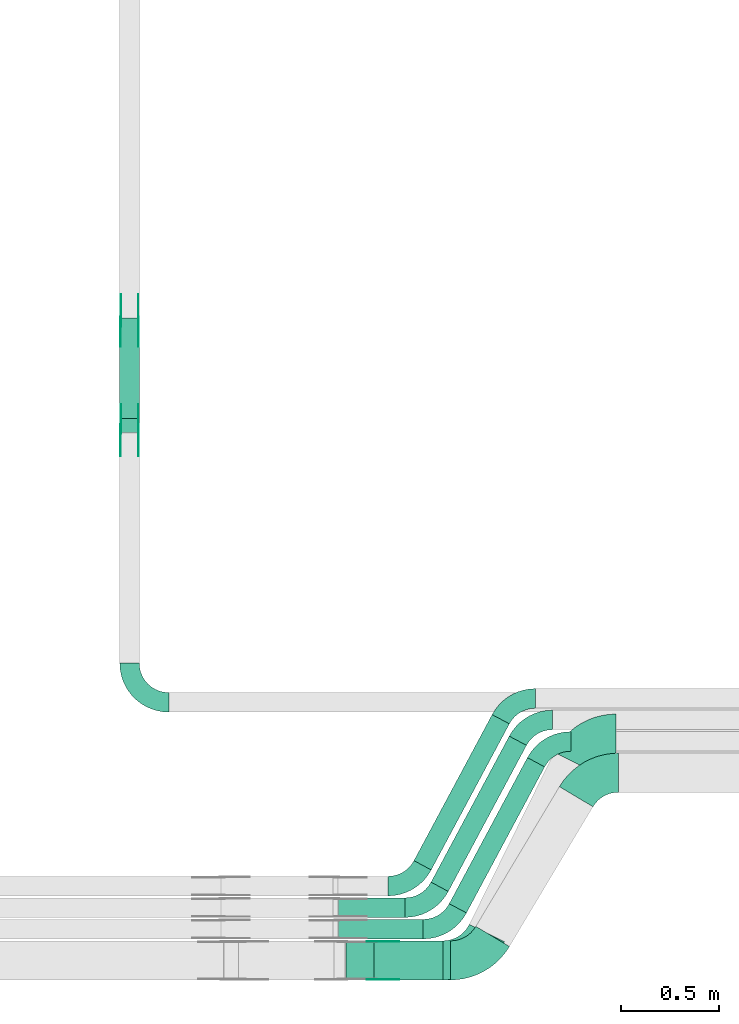
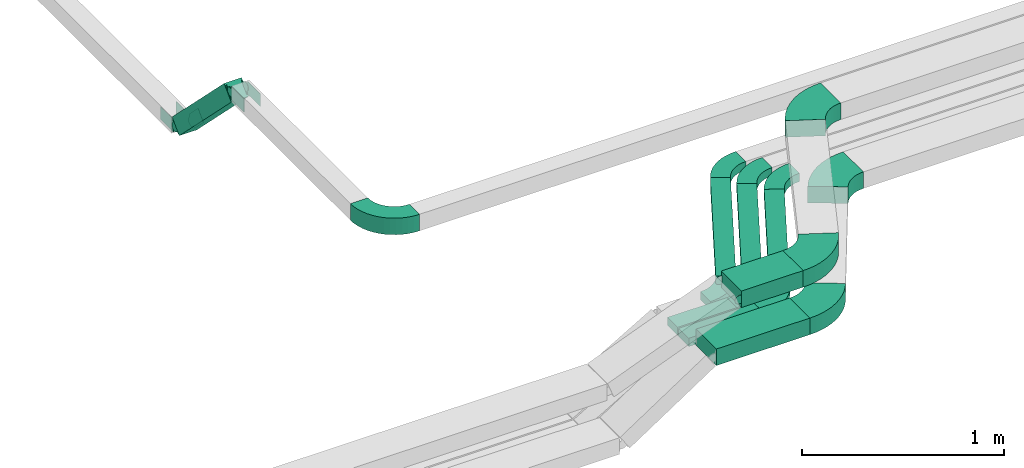
# One storey, part 8 of 23: 21 flow fittings, 8 flow segments.
"""IFC2X3 building model written with IfcOpenShell, lengths in millimetres."""

from ifc_helpers import new_model, entity, si_unit, converted_unit, derived_unit, direction, frame, frame_2d, origin, origin_2d_with_axis, place, context, subcontext, project, spatial, polyline, circle_curve, parameter, trimmed, segment, composite_curve, rectangle, outline, extrude, source, transform, mapped, material, type_object, type_shapes, element, save


model = new_model("IFC2X3")

# Units and contexts
model_context = context("Model", 3, precision=0.01, world=origin(), true_north=direction((6.12303176911189e-17, 1.0)))
body_context = subcontext(model_context, "Body", "Model", "MODEL_VIEW")
ifc_project = project(units=[si_unit("LENGTHUNIT", "METRE", prefix="MILLI"), si_unit("AREAUNIT", "SQUARE_METRE"), si_unit("VOLUMEUNIT", "CUBIC_METRE"), converted_unit("PLANEANGLEUNIT", "DEGREE", entity("IfcRatioMeasure", 0.0174532925199433), si_unit("PLANEANGLEUNIT", "RADIAN"), dimensions=[0, 0, 0, 0, 0, 0, 0]), si_unit("MASSUNIT", "GRAM", prefix="KILO"), derived_unit("MASSDENSITYUNIT", [(si_unit("MASSUNIT", "GRAM", prefix="KILO"), 1), (si_unit("LENGTHUNIT", "METRE"), -3)]), derived_unit("MOMENTOFINERTIAUNIT", [(si_unit("LENGTHUNIT", "METRE"), 4)]), si_unit("TIMEUNIT", "SECOND"), si_unit("FREQUENCYUNIT", "HERTZ"), si_unit("THERMODYNAMICTEMPERATUREUNIT", "DEGREE_CELSIUS"), derived_unit("THERMALTRANSMITTANCEUNIT", [(si_unit("MASSUNIT", "GRAM", prefix="KILO"), 1), (si_unit("THERMODYNAMICTEMPERATUREUNIT", "KELVIN"), -1), (si_unit("TIMEUNIT", "SECOND"), -3)]), derived_unit("VOLUMETRICFLOWRATEUNIT", [(si_unit("LENGTHUNIT", "METRE"), 3), (si_unit("TIMEUNIT", "SECOND"), -1)]), derived_unit("MASSFLOWRATEUNIT", [(si_unit("MASSUNIT", "GRAM", prefix="KILO"), 1), (si_unit("TIMEUNIT", "SECOND"), -1)]), derived_unit("ROTATIONALFREQUENCYUNIT", [(si_unit("TIMEUNIT", "SECOND"), -1)]), si_unit("ELECTRICCURRENTUNIT", "AMPERE"), si_unit("ELECTRICVOLTAGEUNIT", "VOLT"), si_unit("POWERUNIT", "WATT"), si_unit("FORCEUNIT", "NEWTON", prefix="KILO"), si_unit("ILLUMINANCEUNIT", "LUX"), si_unit("LUMINOUSFLUXUNIT", "LUMEN"), si_unit("LUMINOUSINTENSITYUNIT", "CANDELA"), derived_unit("USERDEFINED", [(si_unit("MASSUNIT", "GRAM", prefix="KILO"), -1), (si_unit("LENGTHUNIT", "METRE"), -2), (si_unit("TIMEUNIT", "SECOND"), 3), (si_unit("LUMINOUSFLUXUNIT", "LUMEN"), 1)]), derived_unit("LINEARVELOCITYUNIT", [(si_unit("LENGTHUNIT", "METRE"), 1), (si_unit("TIMEUNIT", "SECOND"), -1)]), si_unit("PRESSUREUNIT", "PASCAL"), derived_unit("USERDEFINED", [(si_unit("LENGTHUNIT", "METRE"), -2), (si_unit("MASSUNIT", "GRAM", prefix="KILO"), 1), (si_unit("TIMEUNIT", "SECOND"), -2)]), derived_unit("LINEARFORCEUNIT", [(si_unit("MASSUNIT", "GRAM", prefix="KILO"), 1), (si_unit("LENGTHUNIT", "METRE"), 1), (si_unit("TIMEUNIT", "SECOND"), -2), (si_unit("LENGTHUNIT", "METRE"), -1)]), derived_unit("PLANARFORCEUNIT", [(si_unit("MASSUNIT", "GRAM", prefix="KILO"), 1), (si_unit("LENGTHUNIT", "METRE"), 1), (si_unit("TIMEUNIT", "SECOND"), -2), (si_unit("LENGTHUNIT", "METRE"), -2)])], contexts=[model_context])

# Site, building, storey
site_placement = place(None, origin())
site = spatial("IfcSite", under=ifc_project, at=site_placement, CompositionType="ELEMENT")
building_placement = place(site_placement, origin())
building = spatial("IfcBuilding", under=site, at=building_placement, CompositionType="ELEMENT")
storey_placement = place(building_placement, frame((0.0, 0.0, 24000.0)))
storey = spatial("IfcBuildingStorey", under=building, at=storey_placement, CompositionType="ELEMENT", Elevation=24000.0)

# Flow segments
cable_carrier_segment_type = type_object("IfcCableCarrierSegmentType", PredefinedType="CABLETRAYSEGMENT")
flow_segment_1_placement = place(storey_placement, frame((41375.11, 2908.93, 3001.17)))
element("IfcFlowSegment", 1, at=flow_segment_1_placement, inside=storey, type_object=cable_carrier_segment_type, context=body_context, shape_type="SweptSolid", body=[
    extrude(rectangle(XDim=100.000000000003, YDim=99.9999999999946, at=frame_2d((0.0, 0.0), x_axis=(0.0, 1.0))), frame((50.0, 549.54, 35.36), z_axis=(0.0, -0.70710678118655, 0.707106781186545), x_axis=(1.0, 0.0, 0.0)), (0.0, 0.0, 1.0), 727.16557414792),
])
flow_segment_2_placement = place(storey_placement, frame((42494.42, 430.0, 3217.23)))
element("IfcFlowSegment", 2, at=flow_segment_2_placement, inside=storey, type_object=cable_carrier_segment_type, context=body_context, shape_type="SweptSolid", body=[
    extrude(rectangle(XDim=338.636913368324, YDim=100.0, at=origin_2d_with_axis()), frame((169.32, 50.0, 0.0)), (0.0, 0.0, 1.0), 49.9999999999973),
])
flow_segment_3_placement = place(storey_placement, frame((42494.42, 320.0, 3217.23)))
element("IfcFlowSegment", 3, at=flow_segment_3_placement, inside=storey, type_object=cable_carrier_segment_type, context=body_context, shape_type="SweptSolid", body=[
    extrude(rectangle(XDim=431.613954254771, YDim=100.0, at=origin_2d_with_axis()), frame((215.81, 50.0, 0.0)), (0.0, 0.0, 1.0), 49.9999999999973),
])
flow_segment_4_placement = place(storey_placement, frame((42530.71, 110.0, 3217.23)))
element("IfcFlowSegment", 4, at=flow_segment_4_placement, inside=storey, type_object=cable_carrier_segment_type, context=body_context, shape_type="SweptSolid", body=[
    extrude(rectangle(XDim=534.96469272526, YDim=200.0, at=origin_2d_with_axis()), frame((267.48, 100.0, 0.0)), (0.0, 0.0, 1.0), 100.000000000003),
])
flow_segment_5_placement = place(storey_placement, frame((42674.36, 110.0, 3517.23)))
element("IfcFlowSegment", 5, at=flow_segment_5_placement, inside=storey, type_object=cable_carrier_segment_type, context=body_context, shape_type="SweptSolid", body=[
    extrude(rectangle(XDim=352.353240473433, YDim=200.0, at=origin_2d_with_axis()), frame((176.18, 100.0, 0.0)), (0.0, 0.0, 1.0), 100.000000000008),
])
flow_segment_6_placement = place(storey_placement, frame((42879.37, 672.88, 3217.23)))
element("IfcFlowSegment", 6, at=flow_segment_6_placement, inside=storey, type_object=cable_carrier_segment_type, context=body_context, shape_type="SweptSolid", body=[
    extrude(rectangle(XDim=847.024364265398, YDim=99.9999999999933, at=origin_2d_with_axis()), frame((243.98, 396.97, 0.0), z_axis=(0.0, 0.0, 1.0), x_axis=(-0.472007051598709, -0.881594772693835, 0.0)), (0.0, 0.0, 1.0), 49.9999999999973),
])
flow_segment_7_placement = place(storey_placement, frame((42966.77, 562.88, 3217.23)))
element("IfcFlowSegment", 7, at=flow_segment_7_placement, inside=storey, type_object=cable_carrier_segment_type, context=body_context, shape_type="SweptSolid", body=[
    extrude(rectangle(XDim=847.024364265391, YDim=99.9999999999915, at=origin_2d_with_axis()), frame((243.98, 396.97, 0.0), z_axis=(0.0, 0.0, 1.0), x_axis=(-0.472007051598681, -0.881594772693849, 0.0)), (0.0, 0.0, 1.0), 49.9999999999973),
])
flow_segment_8_placement = place(storey_placement, frame((43059.75, 452.88, 3217.23)))
element("IfcFlowSegment", 8, at=flow_segment_8_placement, inside=storey, type_object=cable_carrier_segment_type, context=body_context, shape_type="SweptSolid", body=[
    extrude(rectangle(XDim=847.024364265398, YDim=99.9999999999913, at=origin_2d_with_axis()), frame((243.98, 396.97, 0.0), z_axis=(0.0, 0.0, 1.0), x_axis=(0.472007051598678, 0.881594772693851, 0.0)), (0.0, 0.0, 1.0), 49.9999999999973),
])

# Flow fittings
ifc_material_1 = material()
cable_carrier_fitting_type_1 = type_object("IfcCableCarrierFittingType", Name="470_DKC_S5_Variable Angle Elbow 0-45:-", PredefinedType="NOTDEFINED", material=ifc_material_1)
shared_shape_1 = source(origin(), body_context, "Body", "SweptSolid", [
    extrude(outline(composite_curve([segment(polyline([(-100.75, -150.25), (-99.75, -150.25)]), True, "CONTINUOUS"), segment(trimmed(circle_curve(frame_2d((-99.75, 99.75), x_axis=(0.0, -1.0)), 250.0), [parameter(0.0)], [parameter(90.0000000000001)], True, "PARAMETER"), True, "CONTINUOUS"), segment(polyline([(150.25, 99.75), (150.25, 100.75)]), True, "CONTINUOUS"), segment(polyline([(150.25, 100.75), (50.25, 100.75)]), True, "CONTINUOUS"), segment(polyline([(50.25, 100.75), (50.25, 99.75)]), True, "CONTINUOUS"), segment(trimmed(circle_curve(frame_2d((-99.75, 99.75), x_axis=(0.0, -1.0)), 150.0), [parameter(0.0)], [parameter(90.0000000000001)], True, "PARAMETER"), False, "CONTINUOUS"), segment(polyline([(-99.75, -50.25), (-100.75, -50.25)]), True, "CONTINUOUS"), segment(polyline([(-100.75, -50.25), (-100.75, -150.25)]), True, "CONTINUOUS")], self_intersect=False)), frame((-100.25, 100.25, -50.0)), (0.0, 0.0, 1.0), 100.0),
])
type_shapes(cable_carrier_fitting_type_1, [shared_shape_1])
flow_fitting_1_placement = place(storey_placement, frame((41425.11, 1529.69, 3567.23), z_axis=(0.0, 0.0, 1.0), x_axis=(0.0, -1.0, 0.0)))
element("IfcFlowFitting", 9, at=flow_fitting_1_placement, inside=storey, type_object=cable_carrier_fitting_type_1, material=ifc_material_1, Name="470_DKC_S5_Variable Angle Elbow 0-45:-", ObjectType="470_DKC_S5_Variable Angle Elbow 0-45:-", context=body_context, shape_type="MappedRepresentation", body=[
    mapped(shared_shape_1, transform((0.0, 0.0, 0.0), scale=1.0)),
])
ifc_material_2 = material(Name="G")
cable_carrier_fitting_type_2 = type_object("IfcCableCarrierFittingType", PredefinedType="NOTDEFINED", material=ifc_material_2)
shared_shape_2 = source(origin(), body_context, "Body", "SweptSolid", [
    extrude(outline(composite_curve([segment(trimmed(circle_curve(frame_2d((-41.47, 0.0), x_axis=(1.0, 0.0)), 25.0), [parameter(90.0000000000007)], [parameter(270.0)], True, "PARAMETER"), True, "CONTINUOUS"), segment(polyline([(-41.47, -25.0), (-29.97, -25.0)]), True, "CONTINUOUS"), segment(polyline([(-29.97, -25.0), (-28.1, -38.5)]), True, "CONTINUOUS"), segment(polyline([(-28.1, -38.5), (99.53, -38.5)]), True, "CONTINUOUS"), segment(polyline([(99.53, -38.5), (99.53, 38.5)]), True, "CONTINUOUS"), segment(polyline([(99.53, 38.5), (-28.1, 38.5)]), True, "CONTINUOUS"), segment(polyline([(-28.1, 38.5), (-29.97, 25.0)]), True, "CONTINUOUS"), segment(polyline([(-29.97, 25.0), (-41.47, 25.0)]), True, "CONTINUOUS")], self_intersect=False)), frame((41.47, 0.0, 0.0), z_axis=(0.0, 0.0, -1.0), x_axis=(1.0, 0.0, 0.0)), (0.0, 0.0, -1.0), 2.0),
])
type_shapes(cable_carrier_fitting_type_2, [shared_shape_2])
flow_fitting_2_placement = place(storey_placement, frame((41379.65, 3474.99, 3020.0), z_axis=(-1.0, 0.0, 0.0), x_axis=(0.0, -0.707106781186429, 0.707106781186666)))
element("IfcFlowFitting", 10, at=flow_fitting_2_placement, inside=storey, type_object=cable_carrier_fitting_type_2, material=ifc_material_2, context=body_context, shape_type="MappedRepresentation", body=[
    mapped(shared_shape_2, transform((0.0, 0.0, 0.0), scale=1.0)),
])
cable_carrier_fitting_type_3 = type_object("IfcCableCarrierFittingType", PredefinedType="NOTDEFINED", material=ifc_material_2)
type_shapes(cable_carrier_fitting_type_3, [shared_shape_2])
flow_fitting_3_placement = place(storey_placement, frame((41468.57, 3474.99, 3020.0), z_axis=(1.0, 0.0, 0.0), x_axis=(0.0, 1.0, 0.0)))
element("IfcFlowFitting", 11, at=flow_fitting_3_placement, inside=storey, type_object=cable_carrier_fitting_type_3, material=ifc_material_2, context=body_context, shape_type="MappedRepresentation", body=[
    mapped(shared_shape_2, transform((0.0, 0.0, 0.0), scale=1.0)),
])
flow_fitting_4_placement = place(storey_placement, frame((41470.57, 2927.76, 3567.23), z_axis=(1.0, 0.0, 0.0), x_axis=(0.0, -1.0, 0.0)))
element("IfcFlowFitting", 12, at=flow_fitting_4_placement, inside=storey, type_object=cable_carrier_fitting_type_2, material=ifc_material_2, context=body_context, shape_type="MappedRepresentation", body=[
    mapped(shared_shape_2, transform((0.0, 0.0, 0.0), scale=1.0)),
])
flow_fitting_5_placement = place(storey_placement, frame((41381.65, 2927.76, 3567.23), z_axis=(-1.0, 0.0, 0.0), x_axis=(0.0, 0.707106781186541, -0.707106781186554)))
element("IfcFlowFitting", 13, at=flow_fitting_5_placement, inside=storey, type_object=cable_carrier_fitting_type_3, material=ifc_material_2, context=body_context, shape_type="MappedRepresentation", body=[
    mapped(shared_shape_2, transform((0.0, 0.0, 0.0), scale=1.0)),
])
flow_fitting_6_placement = place(storey_placement, frame((42663.17, 305.46, 3567.23), z_axis=(0.0, 1.0, 0.0), x_axis=(1.0, 0.0, 0.0)))
element("IfcFlowFitting", 14, at=flow_fitting_6_placement, inside=storey, type_object=cable_carrier_fitting_type_2, material=ifc_material_2, context=body_context, shape_type="MappedRepresentation", body=[
    mapped(shared_shape_2, transform((0.0, 0.0, 0.0), scale=1.0)),
])
cable_carrier_fitting_type_4 = type_object("IfcCableCarrierFittingType", PredefinedType="NOTDEFINED", material=ifc_material_2)
shared_shape_3 = source(origin(), body_context, "Body", "SweptSolid", [
    extrude(outline(composite_curve([segment(trimmed(circle_curve(frame_2d((-41.47, 0.0), x_axis=(1.0, 0.0)), 25.0), [parameter(90.0000000000007)], [parameter(270.0)], True, "PARAMETER"), True, "CONTINUOUS"), segment(polyline([(-41.47, -25.0), (-29.97, -25.0)]), True, "CONTINUOUS"), segment(polyline([(-29.97, -25.0), (-28.1, -38.5)]), True, "CONTINUOUS"), segment(polyline([(-28.1, -38.5), (99.53, -38.5)]), True, "CONTINUOUS"), segment(polyline([(99.53, -38.5), (99.53, 38.5)]), True, "CONTINUOUS"), segment(polyline([(99.53, 38.5), (-28.1, 38.5)]), True, "CONTINUOUS"), segment(polyline([(-28.1, 38.5), (-29.97, 25.0)]), True, "CONTINUOUS"), segment(polyline([(-29.97, 25.0), (-41.47, 25.0)]), True, "CONTINUOUS")], self_intersect=False)), frame((41.47, 0.0, 0.0)), (0.0, 0.0, 1.0), 2.0),
])
type_shapes(cable_carrier_fitting_type_4, [shared_shape_3])
flow_fitting_7_placement = place(storey_placement, frame((41470.57, 3474.99, 3020.0), z_axis=(1.0, 0.0, 0.0), x_axis=(0.0, -0.707106781186429, 0.707106781186666)))
element("IfcFlowFitting", 15, at=flow_fitting_7_placement, inside=storey, type_object=cable_carrier_fitting_type_4, material=ifc_material_2, context=body_context, shape_type="MappedRepresentation", body=[
    mapped(shared_shape_3, transform((0.0, 0.0, 0.0), scale=1.0)),
])
cable_carrier_fitting_type_5 = type_object("IfcCableCarrierFittingType", PredefinedType="NOTDEFINED", material=ifc_material_2)
type_shapes(cable_carrier_fitting_type_5, [shared_shape_3])
flow_fitting_8_placement = place(storey_placement, frame((41381.65, 3474.99, 3020.0), z_axis=(-1.0, 0.0, 0.0), x_axis=(0.0, 1.0, 0.0)))
element("IfcFlowFitting", 16, at=flow_fitting_8_placement, inside=storey, type_object=cable_carrier_fitting_type_5, material=ifc_material_2, context=body_context, shape_type="MappedRepresentation", body=[
    mapped(shared_shape_3, transform((0.0, 0.0, 0.0), scale=1.0)),
])
flow_fitting_9_placement = place(storey_placement, frame((41379.65, 2927.76, 3567.23), z_axis=(-1.0, 0.0, 0.0), x_axis=(0.0, -1.0, 0.0)))
element("IfcFlowFitting", 17, at=flow_fitting_9_placement, inside=storey, type_object=cable_carrier_fitting_type_4, material=ifc_material_2, context=body_context, shape_type="MappedRepresentation", body=[
    mapped(shared_shape_3, transform((0.0, 0.0, 0.0), scale=1.0)),
])
flow_fitting_10_placement = place(storey_placement, frame((41468.57, 2927.76, 3567.23), z_axis=(1.0, 0.0, 0.0), x_axis=(0.0, 0.707106781186541, -0.707106781186554)))
element("IfcFlowFitting", 18, at=flow_fitting_10_placement, inside=storey, type_object=cable_carrier_fitting_type_5, material=ifc_material_2, context=body_context, shape_type="MappedRepresentation", body=[
    mapped(shared_shape_3, transform((0.0, 0.0, 0.0), scale=1.0)),
])
flow_fitting_11_placement = place(storey_placement, frame((42663.17, 114.54, 3567.23), z_axis=(0.0, -1.0, 0.0), x_axis=(1.0, 0.0, 0.0)))
element("IfcFlowFitting", 19, at=flow_fitting_11_placement, inside=storey, type_object=cable_carrier_fitting_type_4, material=ifc_material_2, context=body_context, shape_type="MappedRepresentation", body=[
    mapped(shared_shape_3, transform((0.0, 0.0, 0.0), scale=1.0)),
])
cable_carrier_fitting_type_6 = type_object("IfcCableCarrierFittingType", Name="470_DKC_S5_Variable Angle Elbow 0-45:-", PredefinedType="NOTDEFINED", material=ifc_material_1)
shared_shape_4 = source(origin(), body_context, "Body", "SweptSolid", [
    extrude(outline(composite_curve([segment(polyline([(-89.03, -103.02), (-88.03, -103.02)]), True, "CONTINUOUS"), segment(trimmed(circle_curve(frame_2d((-88.03, 146.98), x_axis=(0.0, -1.0)), 250.0), [parameter(0.0)], [parameter(61.8353423405045)], True, "PARAMETER"), True, "CONTINUOUS"), segment(polyline([(132.37, 28.98), (132.84, 29.86)]), True, "CONTINUOUS"), segment(polyline([(132.84, 29.86), (44.68, 77.06)]), True, "CONTINUOUS"), segment(polyline([(44.68, 77.06), (44.21, 76.18)]), True, "CONTINUOUS"), segment(trimmed(circle_curve(frame_2d((-88.03, 146.98), x_axis=(0.0, -1.0)), 150.0), [parameter(0.0)], [parameter(61.8353423405045)], True, "PARAMETER"), False, "CONTINUOUS"), segment(polyline([(-88.03, -3.02), (-89.03, -3.02)]), True, "CONTINUOUS"), segment(polyline([(-89.03, -3.02), (-89.03, -103.02)]), True, "CONTINUOUS")], self_intersect=False)), frame((-31.75, 53.02, -25.0)), (0.0, 0.0, 1.0), 49.9999999999998),
])
type_shapes(cable_carrier_fitting_type_6, [shared_shape_4])
for number, where, name in (
    (20, (42866.44, 590.0, 3242.23), "470_DKC_S5_Variable Angle Elbow 0-45:-"),
    (21, (42953.84, 480.0, 3242.23), "470_DKC_S5_Variable Angle Elbow 0-45:-"),
    (22, (43046.82, 370.0, 3242.23), "470_DKC_S5_Variable Angle Elbow 0-45:-"),
):
    element("IfcFlowFitting", number, at=place(storey_placement, frame(where)), inside=storey, type_object=cable_carrier_fitting_type_6, material=ifc_material_1, Name=name, ObjectType="470_DKC_S5_Variable Angle Elbow 0-45:-", context=body_context, shape_type="MappedRepresentation", body=[
        mapped(shared_shape_4, transform((0.0, 0.0, 0.0), scale=1.0)),
    ])
for number, where, z_axis, x_axis, name in (
    (23, (43560.64, 1329.69, 3242.23), (0.0, 0.0, 1.0), (-1.0, 0.0, 0.0), "470_DKC_S5_Variable Angle Elbow 0-45:-"),
    (24, (43467.66, 1439.69, 3242.23), (0.0, 0.0, 1.0), (-1.0, 0.0, 0.0), "470_DKC_S5_Variable Angle Elbow 0-45:-"),
    (25, (43380.26, 1549.69, 3242.23), (0.0, 0.0, 1.0), (-1.0, 0.0, 0.0), "470_DKC_S5_Variable Angle Elbow 0-45:-"),
):
    element("IfcFlowFitting", number, at=place(storey_placement, frame(where, z_axis=z_axis, x_axis=x_axis)), inside=storey, type_object=cable_carrier_fitting_type_6, material=ifc_material_1, Name=name, ObjectType="470_DKC_S5_Variable Angle Elbow 0-45:-", context=body_context, shape_type="MappedRepresentation", body=[
        mapped(shared_shape_4, transform((0.0, 0.0, 0.0), scale=1.0)),
    ])
cable_carrier_fitting_type_7 = type_object("IfcCableCarrierFittingType", Name="470_DKC_S5_Variable Angle Elbow 0-45:-", PredefinedType="NOTDEFINED", material=ifc_material_1)
shared_shape_5 = source(origin(), body_context, "Body", "SweptSolid", [
    extrude(outline(composite_curve([segment(polyline([(-108.18, -161.09), (-107.18, -161.09)]), True, "CONTINUOUS"), segment(trimmed(circle_curve(frame_2d((-107.18, 188.91), x_axis=(0.0, -1.0)), 350.0), [parameter(0.0)], [parameter(59.1366247749536)], True, "PARAMETER"), True, "CONTINUOUS"), segment(polyline([(193.26, 9.36), (193.77, 10.22)]), True, "CONTINUOUS"), segment(polyline([(193.77, 10.22), (22.09, 112.82)]), True, "CONTINUOUS"), segment(polyline([(22.09, 112.82), (21.58, 111.96)]), True, "CONTINUOUS"), segment(trimmed(circle_curve(frame_2d((-107.18, 188.91), x_axis=(0.0, -1.0)), 150.0), [parameter(0.0)], [parameter(59.1366247749536)], True, "PARAMETER"), False, "CONTINUOUS"), segment(polyline([(-107.18, 38.91), (-108.18, 38.91)]), True, "CONTINUOUS"), segment(polyline([(-108.18, 38.91), (-108.18, -161.09)]), True, "CONTINUOUS")], self_intersect=False)), frame((-34.66, 61.09, -50.0)), (0.0, 0.0, 1.0), 100.0),
])
type_shapes(cable_carrier_fitting_type_7, [shared_shape_5])
flow_fitting_12_placement = place(storey_placement, frame((43782.04, 1169.69, 3267.23), z_axis=(0.0, 0.0, 1.0), x_axis=(-1.0, 0.0, 0.0)))
element("IfcFlowFitting", 26, at=flow_fitting_12_placement, inside=storey, type_object=cable_carrier_fitting_type_7, material=ifc_material_1, Name="470_DKC_S5_Variable Angle Elbow 0-45:-", ObjectType="470_DKC_S5_Variable Angle Elbow 0-45:-", context=body_context, shape_type="MappedRepresentation", body=[
    mapped(shared_shape_5, transform((0.0, 0.0, 0.0), scale=1.0)),
])
flow_fitting_13_placement = place(storey_placement, frame((43208.51, 210.0, 3267.23)))
element("IfcFlowFitting", 27, at=flow_fitting_13_placement, inside=storey, type_object=cable_carrier_fitting_type_7, material=ifc_material_1, Name="470_DKC_S5_Variable Angle Elbow 0-45:-", ObjectType="470_DKC_S5_Variable Angle Elbow 0-45:-", context=body_context, shape_type="MappedRepresentation", body=[
    mapped(shared_shape_5, transform((0.0, 0.0, 0.0), scale=1.0)),
])
cable_carrier_fitting_type_8 = type_object("IfcCableCarrierFittingType", Name="470_DKC_S5_Variable Angle Elbow 0-45:-", PredefinedType="NOTDEFINED", material=ifc_material_1)
shared_shape_6 = source(origin(), body_context, "Body", "SweptSolid", [
    extrude(outline(composite_curve([segment(polyline([(-112.97, -169.93), (-111.97, -169.93)]), True, "CONTINUOUS"), segment(trimmed(circle_curve(frame_2d((-111.97, 180.07), x_axis=(0.0, -1.0)), 350.0), [parameter(0.0)], [parameter(63.7483130924797)], True, "PARAMETER"), True, "CONTINUOUS"), segment(polyline([(201.93, 25.25), (202.38, 26.15)]), True, "CONTINUOUS"), segment(polyline([(202.38, 26.15), (23.0, 114.61)]), True, "CONTINUOUS"), segment(polyline([(23.0, 114.61), (22.56, 113.72)]), True, "CONTINUOUS"), segment(trimmed(circle_curve(frame_2d((-111.97, 180.07), x_axis=(0.0, -1.0)), 150.0), [parameter(0.0)], [parameter(63.7483130924797)], True, "PARAMETER"), False, "CONTINUOUS"), segment(polyline([(-111.97, 30.07), (-112.97, 30.07)]), True, "CONTINUOUS"), segment(polyline([(-112.97, 30.07), (-112.97, -169.93)]), True, "CONTINUOUS")], self_intersect=False)), frame((-43.49, 69.93, -50.0)), (0.0, 0.0, 1.0), 100.0),
])
type_shapes(cable_carrier_fitting_type_8, [shared_shape_6])
flow_fitting_14_placement = place(storey_placement, frame((43183.17, 210.0, 3567.23)))
element("IfcFlowFitting", 28, at=flow_fitting_14_placement, inside=storey, type_object=cable_carrier_fitting_type_8, material=ifc_material_1, Name="470_DKC_S5_Variable Angle Elbow 0-45:-", ObjectType="470_DKC_S5_Variable Angle Elbow 0-45:-", context=body_context, shape_type="MappedRepresentation", body=[
    mapped(shared_shape_6, transform((0.0, 0.0, 0.0), scale=1.0)),
])
flow_fitting_15_placement = place(storey_placement, frame((43755.11, 1369.69, 3567.23), z_axis=(0.0, 0.0, 1.0), x_axis=(-1.0, 0.0, 0.0)))
element("IfcFlowFitting", 29, at=flow_fitting_15_placement, inside=storey, type_object=cable_carrier_fitting_type_8, material=ifc_material_1, Name="470_DKC_S5_Variable Angle Elbow 0-45:-", ObjectType="470_DKC_S5_Variable Angle Elbow 0-45:-", context=body_context, shape_type="MappedRepresentation", body=[
    mapped(shared_shape_6, transform((0.0, 0.0, 0.0), scale=1.0)),
])

save(model, "model.ifc")
